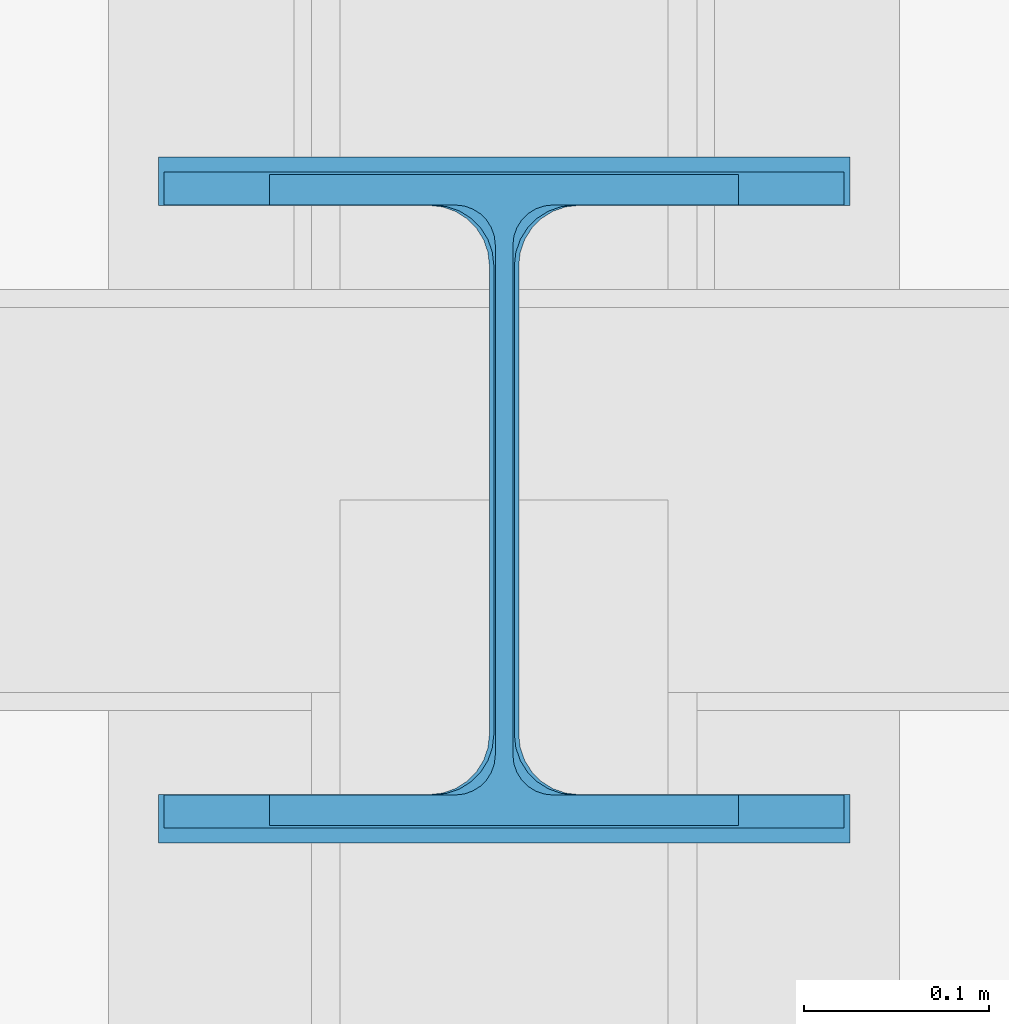
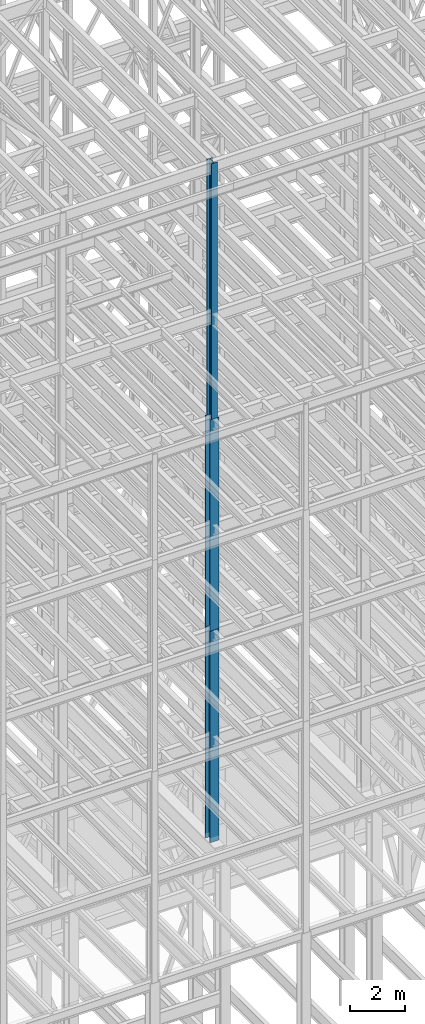
# One storey, part 34 of 150: 3 columns.
"""IFC2X3 building model written with IfcOpenShell, lengths in millimetres."""

import ifcopenshell
import ifcopenshell.guid

model = None  # the IFC model being written
_history = None  # IfcOwnerHistory: only IFC2X3 demands one
_inside = {}  # id of a spatial element -> (the spatial element, [elements in it])
_under = {}  # id of a project, library or spatial element -> (it, [spatial elements below it])
_declared = {}  # id of a project -> (the project, [libraries it declares])
_typed = {}  # id of a type object -> (the type object, [elements of that type])
_made_of = {}  # id of a material, layer set ... -> (it, [elements and type objects made of it])


def new_model(schema):
    """Start an empty IFC model of exactly this schema.

    Asked for "IFC4X3", IfcOpenShell would pick the latest addendum, in which some entities
    have other attributes; the version numbers below select the first issue.
    IFC2X3 requires an IfcOwnerHistory on every rooted entity: one is made here for all.
    """
    global model, _history
    if schema == "IFC4X3":
        model = ifcopenshell.file(schema_version=(4, 3, 0, 0))
    else:
        model = ifcopenshell.file(schema=schema)
    _inside.clear()
    _under.clear()
    _declared.clear()
    _typed.clear()
    _made_of.clear()
    _history = None
    if model.schema == "IFC2X3":
        org = make("IfcOrganization", Name="unknown")
        user = make(
            "IfcPersonAndOrganization",
            ThePerson=make("IfcPerson", FamilyName="unknown"),
            TheOrganization=org,
        )
        app = make(
            "IfcApplication",
            ApplicationDeveloper=org,
            Version="unknown",
            ApplicationFullName="unknown",
            ApplicationIdentifier="unknown",
        )
        _history = make(
            "IfcOwnerHistory",
            OwningUser=user,
            OwningApplication=app,
            ChangeAction="ADDED",
            CreationDate=0,
        )
    return model


def make(cls, **values):
    """One entity of the class cls with the attributes given. An attribute that is None is left unset."""
    return model.create_entity(
        cls, **{name: value for name, value in values.items() if value is not None}
    )


def rooted(cls, **values):
    """An entity with a GlobalId (a new one), such as an element, a storey or a relation."""
    return make(cls, GlobalId=ifcopenshell.guid.new(), OwnerHistory=_history, **values)


def si_unit(unit_type, name, prefix=None):
    """IfcSIUnit, for example si_unit("LENGTHUNIT", "METRE", prefix="MILLI")."""
    return make("IfcSIUnit", UnitType=unit_type, Prefix=prefix, Name=name)


def assignment(units):
    """IfcUnitAssignment: the units of a project."""
    return None if units is None else make("IfcUnitAssignment", Units=units)


def point(xyz):
    """IfcCartesianPoint."""
    return None if xyz is None else make("IfcCartesianPoint", Coordinates=xyz)


def direction(xyz):
    """IfcDirection."""
    return None if xyz is None else make("IfcDirection", DirectionRatios=xyz)


def frame(location, z_axis=None, x_axis=None):
    """IfcAxis2Placement3D, a coordinate frame: its origin and axes. An axis left out is left unset."""
    return make(
        "IfcAxis2Placement3D",
        Location=point(location),
        Axis=direction(z_axis),
        RefDirection=direction(x_axis),
    )


def frame_2d(location, x_axis=None):
    """IfcAxis2Placement2D, a coordinate frame in the plane: its origin and x axis."""
    return make(
        "IfcAxis2Placement2D", Location=point(location), RefDirection=direction(x_axis)
    )


def origin_with_axes():
    """The frame at (0, 0, 0) with the z axis (0, 0, 1) and the x axis (1, 0, 0) written out."""
    return frame((0.0, 0.0, 0.0), z_axis=(0.0, 0.0, 1.0), x_axis=(1.0, 0.0, 0.0))


def origin_2d_with_axis():
    """The frame at (0, 0) in the plane with the x axis (1, 0) written out."""
    return frame_2d((0.0, 0.0), x_axis=(1.0, 0.0))


def place(relative_to, where):
    """IfcLocalPlacement: puts the frame where relative to a parent placement (None: the world)."""
    return make(
        "IfcLocalPlacement", PlacementRelTo=relative_to, RelativePlacement=where
    )


def context(
    kind, dimensions, precision=None, world=None, true_north=None, identifier=None
):
    """IfcGeometricRepresentationContext, for example the 3D "Model" context."""
    return make(
        "IfcGeometricRepresentationContext",
        ContextIdentifier=identifier,
        ContextType=kind,
        CoordinateSpaceDimension=dimensions,
        Precision=precision,
        WorldCoordinateSystem=world,
        TrueNorth=true_north,
    )


def subcontext(parent, identifier, kind, view, scale=None):
    """IfcGeometricRepresentationSubContext, for example "Body" below "Model"."""
    return make(
        "IfcGeometricRepresentationSubContext",
        ContextIdentifier=identifier,
        ContextType=kind,
        ParentContext=parent,
        TargetScale=scale,
        TargetView=view,
    )


def project(units=None, contexts=None):
    """IfcProject with its units and contexts."""
    return rooted(
        "IfcProject",
        Name="project",
        RepresentationContexts=contexts,
        UnitsInContext=assignment(units),
    )


def spatial(cls, under=None, at=None, **own):
    """A site, building, storey or space (cls), placed at a placement, below another one or the project."""
    s = rooted(cls, ObjectPlacement=at, **own)
    if under is not None:
        _under.setdefault(under.id(), (under, []))[1].append(s)
    return s


def profile(cls, at=None, kind="AREA", **sizes):
    """A parametric profile (cls). Its sizes go by their IFC names, for example OverallWidth=200.0."""
    return make(cls, ProfileType=kind, Position=at, **sizes)


def i_section(**sizes):
    """IfcIShapeProfileDef."""
    return profile("IfcIShapeProfileDef", **sizes)


def extrude(swept, where, along, depth):
    """IfcExtrudedAreaSolid: the profile swept, set in the frame where, extruded along a direction by depth."""
    return make(
        "IfcExtrudedAreaSolid",
        SweptArea=swept,
        Position=where,
        ExtrudedDirection=direction(along),
        Depth=depth,
    )


def shape(context_of_items, identifier, shape_type, items):
    """IfcShapeRepresentation: the items that make up one representation, for example the "Body"."""
    return make(
        "IfcShapeRepresentation",
        ContextOfItems=context_of_items,
        RepresentationIdentifier=identifier,
        RepresentationType=shape_type,
        Items=items,
    )


def material(Name=None, Category=None):
    """IfcMaterial."""
    return make("IfcMaterial", Name=Name, Category=Category)


def made_of(thing, what):
    """Note that an element or type object is made of a material, layer set ...; save() writes the relation."""
    if what is not None:
        _made_of.setdefault(what.id(), (what, []))[1].append(thing)
    return thing


def type_object(cls, material=None, **own):
    """A type object (cls), such as IfcWallType, which elements share."""
    return made_of(rooted(cls, **own), material)


def element(
    cls,
    number,
    at=None,
    inside=None,
    cuts=None,
    type_object=None,
    material=None,
    context=None,
    identifier="Body",
    shape_type=None,
    held_by="IfcProductDefinitionShape",
    body=None,
    shapes=None,
    **own,
):
    """One element of the class cls, such as IfcWall. Its Tag is "e" and its number.

    at: its placement. inside: the storey or other place that contains it. cuts: it is an
    opening in that element (IfcRelVoidsElement). A single representation is given by context,
    identifier, shape_type and body (its items); several are given by shapes. held_by: the class
    of the entity that holds the representations. save() writes the other relations.
    """
    e = rooted(cls, Tag="e%d" % number, ObjectPlacement=at, **own)
    if body is not None:
        shapes = [shape(context, identifier, shape_type, body)]
    if shapes is not None:
        e.Representation = make(held_by, Representations=shapes)
    if inside is not None:
        _inside.setdefault(inside.id(), (inside, []))[1].append(e)
    if cuts is not None:
        rooted(
            "IfcRelVoidsElement", RelatingBuildingElement=cuts, RelatedOpeningElement=e
        )
    if type_object is not None:
        _typed.setdefault(type_object.id(), (type_object, []))[1].append(e)
    return made_of(e, material)


def aggregate(whole, parts):
    """IfcRelAggregates: a whole, such as a stair, and the parts it consists of."""
    return rooted("IfcRelAggregates", RelatingObject=whole, RelatedObjects=parts)


def save(model, path):
    """Write the relations noted so far, then the file.

    IfcRelAggregates (storeys below a building ...), IfcRelContainedInSpatialStructure (elements
    in a storey), IfcRelDefinesByType, IfcRelAssociatesMaterial and IfcRelDeclares: one each for
    every whole, place, type object, material and project.
    """
    for whole, parts in _under.values():
        aggregate(whole, parts)
    for where, things in _inside.values():
        rooted(
            "IfcRelContainedInSpatialStructure",
            RelatedElements=things,
            RelatingStructure=where,
        )
    for kind, things in _typed.values():
        rooted("IfcRelDefinesByType", RelatedObjects=things, RelatingType=kind)
    for what, things in _made_of.values():
        rooted("IfcRelAssociatesMaterial", RelatedObjects=things, RelatingMaterial=what)
    for by, libraries in _declared.values():
        rooted("IfcRelDeclares", RelatingContext=by, RelatedDefinitions=libraries)
    model.write(path)


model = new_model("IFC2X3")

# Units and contexts
model_context = context("Model", 3, precision=1e-05, world=origin_with_axes())
body_context = subcontext(model_context, "Body", "Model", "MODEL_VIEW")
ifc_project = project(units=[si_unit("LENGTHUNIT", "METRE", prefix="MILLI"), si_unit("AREAUNIT", "SQUARE_METRE"), si_unit("VOLUMEUNIT", "CUBIC_METRE"), si_unit("MASSUNIT", "GRAM", prefix="KILO"), si_unit("TIMEUNIT", "SECOND"), si_unit("PLANEANGLEUNIT", "RADIAN"), si_unit("SOLIDANGLEUNIT", "STERADIAN"), si_unit("THERMODYNAMICTEMPERATUREUNIT", "DEGREE_CELSIUS"), si_unit("LUMINOUSINTENSITYUNIT", "LUMEN")], contexts=[model_context])

# Site, building, storey
site_placement = place(None, origin_with_axes())
site = spatial("IfcSite", under=ifc_project, at=site_placement, CompositionType="ELEMENT")
building_placement = place(site_placement, origin_with_axes())
building = spatial("IfcBuilding", under=site, at=building_placement, Name="Undefined", CompositionType="ELEMENT")
storey_placement = place(building_placement, origin_with_axes())
storey = spatial("IfcBuildingStorey", under=building, at=storey_placement, Name="Undefined", CompositionType="ELEMENT", Elevation=0.0)

# Columns
ifc_material = material(Name="STEEL/A992")
column_type_1 = type_object("IfcColumnType", Name="W14X61", PredefinedType="NOTDEFINED")
column_1_placement = place(storey_placement, frame((56591.2, 10185.4, 54483.0), z_axis=(0.0, 0.0, 1.0), x_axis=(1.0, 0.0, 0.0)))
element("IfcColumn", 1, at=column_1_placement, inside=storey, type_object=column_type_1, material=ifc_material, Name="COLUMN", ObjectType="W14X61", context=body_context, shape_type="SweptSolid", body=[
    extrude(i_section(OverallWidth=254.0, OverallDepth=352.425, WebThickness=9.5249, FlangeThickness=16.383, FilletRadius=21.717, at=origin_2d_with_axis()), frame((0.0, 0.0, 11429.998857), z_axis=(0.0, 0.0, -1.0), x_axis=(-1.0, 0.0, 0.0)), (0.0, 0.0, 1.0), 11429.998857),
])
column_type_2 = type_object("IfcColumnType", Name="W14X132", PredefinedType="NOTDEFINED")
column_2_placement = place(storey_placement, frame((56591.2, 10185.4, 35585.4), z_axis=(0.0, 0.0, 1.0), x_axis=(1.0, 0.0, 0.0)))
element("IfcColumn", 2, at=column_2_placement, inside=storey, type_object=column_type_2, material=ifc_material, Name="COLUMN", ObjectType="W14X132", context=body_context, shape_type="SweptSolid", body=[
    extrude(i_section(OverallWidth=374.65, OverallDepth=371.475, WebThickness=15.875, FlangeThickness=26.162, FilletRadius=32.5755, at=origin_2d_with_axis()), frame((0.0, 0.0, 9448.8009448801), z_axis=(0.0, 0.0, -1.0), x_axis=(-1.0, 0.0, 0.0)), (0.0, 0.0, 1.0), 9448.8009448801),
])
column_type_3 = type_object("IfcColumnType", Name="W14X90", PredefinedType="NOTDEFINED")
column_3_placement = place(storey_placement, frame((56591.2, 10185.4, 45034.2009448801), z_axis=(0.0, 0.0, 1.0), x_axis=(1.0, 0.0, 0.0)))
element("IfcColumn", 3, at=column_3_placement, inside=storey, type_object=column_type_3, material=ifc_material, Name="COLUMN", ObjectType="W14X90", context=body_context, shape_type="SweptSolid", body=[
    extrude(i_section(OverallWidth=368.3, OverallDepth=355.6, WebThickness=11.1125, FlangeThickness=18.034, FilletRadius=32.7659, at=origin_2d_with_axis()), frame((0.0, 0.0, 9448.79811024001), z_axis=(0.0, 0.0, -1.0), x_axis=(-1.0, 0.0, 0.0)), (0.0, 0.0, 1.0), 9448.79811024001),
])

save(model, "model.ifc")
